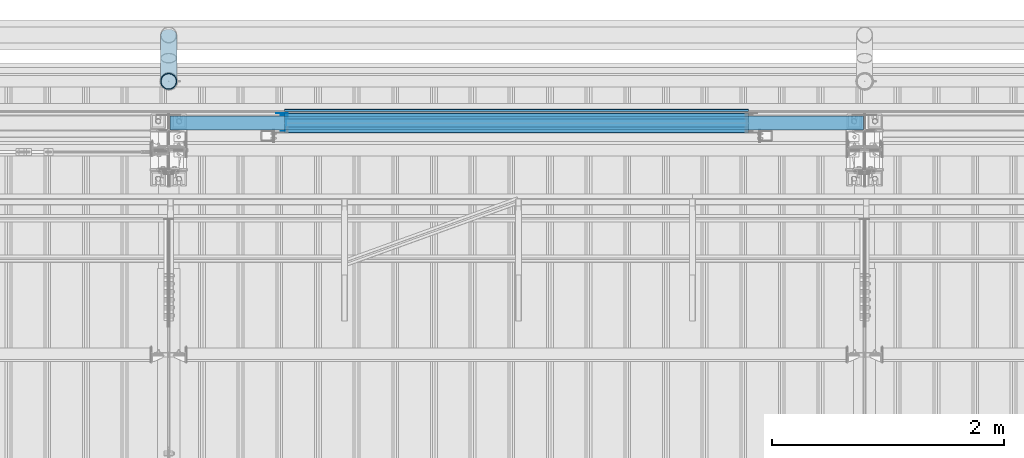
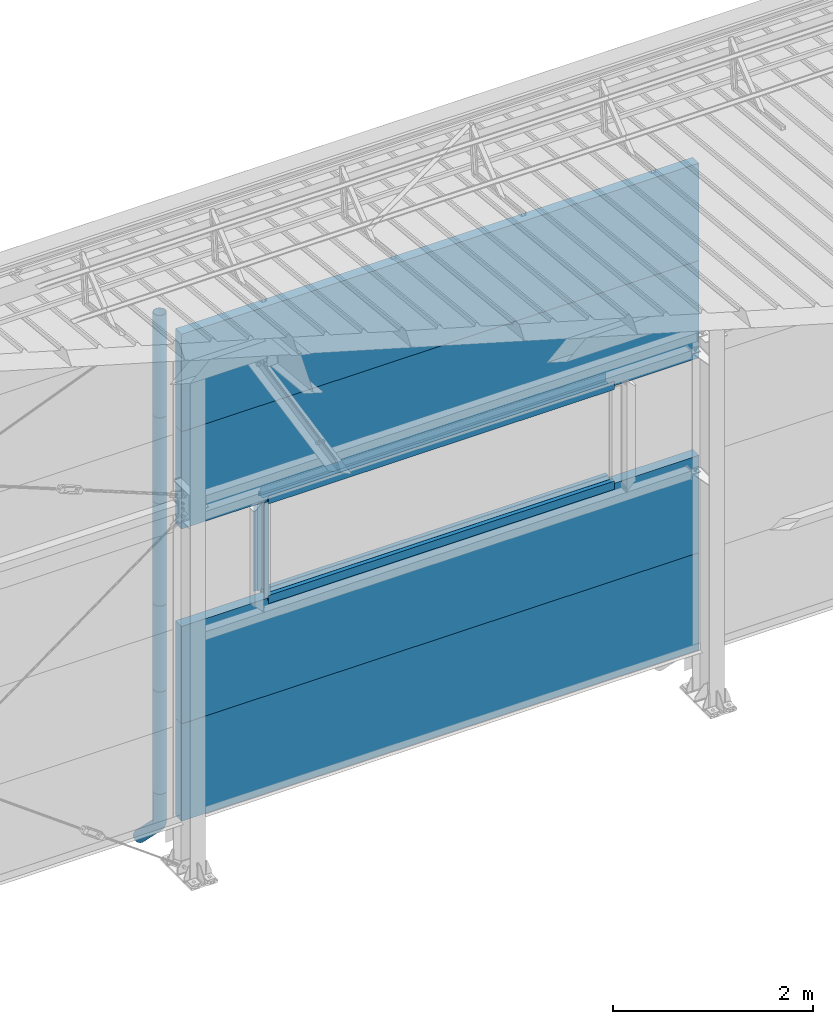
# One storey, part 62 of 709: 19 beams, 19 elements without a shape of their own.
"""IFC4 building model written with IfcOpenShell, lengths in millimetres."""

from ifc_helpers import new_model, entity, si_unit, direction, frame, origin_with_axes, place, context, subcontext, project, spatial, line, indexed_curve, outline, extrude, material, element, aggregate, save


model = new_model("IFC4")

# Units and contexts
model_context = context("Model", 3, precision=0.2, world=origin_with_axes(), true_north=direction((0.0, 1.0)))
body_context = subcontext(model_context, "Body", "Model", "MODEL_VIEW")
ifc_project = project(units=[si_unit("LENGTHUNIT", "METRE", prefix="MILLI"), si_unit("AREAUNIT", "SQUARE_METRE"), si_unit("VOLUMEUNIT", "CUBIC_METRE"), si_unit("MASSUNIT", "GRAM", prefix="KILO"), si_unit("TIMEUNIT", "SECOND"), si_unit("PLANEANGLEUNIT", "RADIAN"), si_unit("SOLIDANGLEUNIT", "STERADIAN"), si_unit("THERMODYNAMICTEMPERATUREUNIT", "DEGREE_CELSIUS"), si_unit("LUMINOUSINTENSITYUNIT", "LUMEN")], contexts=[model_context])

# Site, building, storey
site_placement = place(None, origin_with_axes())
site = spatial("IfcSite", under=ifc_project, at=site_placement, CompositionType="ELEMENT")
building_placement = place(site_placement, origin_with_axes())
building = spatial("IfcBuilding", under=site, at=building_placement, Name="Undefined", CompositionType="ELEMENT")
storey_placement = place(building_placement, origin_with_axes())
storey = spatial("IfcBuildingStorey", under=building, at=storey_placement, Name="Undefined", CompositionType="ELEMENT", Elevation=0.0)

# Assembly, beam
assembly_1_placement = place(storey_placement, frame((28010.0, 22060.0, 895.0), z_axis=(0.0, 0.0, -1.0), x_axis=(1.0, 0.0, 0.0)))
assembly_1 = element("IfcElementAssembly", 1, at=assembly_1_placement, inside=storey)
ifc_material_1 = material(Name="Insulation", Category="Insulation")
beam_1_placement = place(assembly_1_placement, origin_with_axes())
beam_1 = element("IfcBeam", 2, at=beam_1_placement, material=ifc_material_1, ObjectType="P-107", context=body_context, shape_type="SolidModel", body=[
    extrude(outline(indexed_curve([(-595.0, -60.0), (595.0, -60.0), (595.0, 60.0), (-595.0, 60.0)], segments=[line(1, 2, 3, 4, 1)])), frame((0.0, 0.0, 0.0), z_axis=(-1.0, 0.0, 0.0), x_axis=(0.0, 0.0, 1.0)), (0.0, 0.0, -1.0), 5980.0),
])
aggregate(assembly_1, [beam_1])

assembly_2_placement = place(storey_placement, frame((28010.0, 22060.0, 2085.0), z_axis=(0.0, 0.0, -1.0), x_axis=(1.0, 0.0, 0.0)))
assembly_2 = element("IfcElementAssembly", 3, at=assembly_2_placement, inside=storey)
beam_2_placement = place(assembly_2_placement, origin_with_axes())
beam_2 = element("IfcBeam", 4, at=beam_2_placement, material=ifc_material_1, ObjectType="P-107", context=body_context, shape_type="SolidModel", body=[
    extrude(outline(indexed_curve([(-595.0, -60.0), (595.0, -60.0), (595.0, 60.0), (-595.0, 60.0)], segments=[line(1, 2, 3, 4, 1)])), frame((0.0, 0.0, 0.0), z_axis=(-1.0, 0.0, 0.0), x_axis=(0.0, 0.0, 1.0)), (0.0, 0.0, -1.0), 5980.0),
])
aggregate(assembly_2, [beam_2])

assembly_3_placement = place(storey_placement, frame((28010.0, 22060.0, 4465.0), z_axis=(0.0, 0.0, -1.0), x_axis=(1.0, 0.0, 0.0)))
assembly_3 = element("IfcElementAssembly", 5, at=assembly_3_placement, inside=storey)
beam_3_placement = place(assembly_3_placement, origin_with_axes())
beam_3 = element("IfcBeam", 6, at=beam_3_placement, material=ifc_material_1, ObjectType="P-107", context=body_context, shape_type="SolidModel", body=[
    extrude(outline(indexed_curve([(-595.0, -60.0), (595.0, -60.0), (595.0, 60.0), (-595.0, 60.0)], segments=[line(1, 2, 3, 4, 1)])), frame((0.0, 0.0, 0.0), z_axis=(-1.0, 0.0, 0.0), x_axis=(0.0, 0.0, 1.0)), (0.0, 0.0, -1.0), 5980.0),
])
aggregate(assembly_3, [beam_3])

assembly_4_placement = place(storey_placement, frame((28010.0, 22060.0, 5655.0), z_axis=(0.0, 0.0, -1.0), x_axis=(1.0, 0.0, 0.0)))
assembly_4 = element("IfcElementAssembly", 7, at=assembly_4_placement, inside=storey)
beam_4_placement = place(assembly_4_placement, origin_with_axes())
beam_4 = element("IfcBeam", 8, at=beam_4_placement, material=ifc_material_1, ObjectType="P-107", context=body_context, shape_type="SolidModel", body=[
    extrude(outline(indexed_curve([(-595.0, -60.0), (595.0, -60.0), (595.0, 60.0), (-595.0, 60.0)], segments=[line(1, 2, 3, 4, 1)])), frame((0.0, 0.0, 0.0), z_axis=(-1.0, 0.0, 0.0), x_axis=(0.0, 0.0, 1.0)), (0.0, 0.0, -1.0), 5980.0),
])
aggregate(assembly_4, [beam_4])

assembly_5_placement = place(storey_placement, frame((33000.0, 22001.0, 2725.0), z_axis=(0.0, -1.0, 0.0), x_axis=(-1.0, 0.0, 0.0)))
assembly_5 = element("IfcElementAssembly", 9, at=assembly_5_placement, inside=storey)
ifc_material_2 = material(Name="Steel_Undefined", Category="STEEL")
beam_5_placement = place(assembly_5_placement, origin_with_axes())
beam_5 = element("IfcBeam", 10, at=beam_5_placement, material=ifc_material_2, context=body_context, shape_type="SolidModel", body=[
    extrude(outline(indexed_curve([(-25.0, -1.0), (25.0, -1.0), (25.0, 99.0), (23.0, 99.0), (23.0, 1.0), (-25.0, 1.0)], segments=[line(1, 2, 3, 4, 5, 6, 1)])), frame((0.0, 0.0, 0.0), z_axis=(-1.0, 0.0, 0.0), x_axis=(0.0, 0.0, 1.0)), (0.0, 0.0, -1.0), 4000.0),
])
aggregate(assembly_5, [beam_5])

assembly_6_placement = place(storey_placement, frame((33000.0, 22060.0, 2680.0), z_axis=(0.0, 1.0, 0.0), x_axis=(-1.0, 0.0, 0.0)))
assembly_6 = element("IfcElementAssembly", 11, at=assembly_6_placement, inside=storey)
beam_6_placement = place(assembly_6_placement, origin_with_axes())
beam_6 = element("IfcBeam", 12, at=beam_6_placement, material=ifc_material_2, context=body_context, shape_type="SolidModel", body=[
    extrude(outline(indexed_curve([(-70.0, -25.0), (-68.0, -25.0), (-68.0, 23.0), (68.0, 23.0), (68.0, -25.0), (70.0, -25.0), (70.0, 25.0), (-70.0, 25.0)], segments=[line(1, 2, 3, 4, 5, 6, 7, 8, 1)])), frame((0.0, 0.0, 0.0), z_axis=(-1.0, 0.0, 0.0), x_axis=(0.0, 0.0, 1.0)), (0.0, 0.0, -1.0), 4000.0),
])
aggregate(assembly_6, [beam_6])

assembly_7_placement = place(storey_placement, frame((29000.0, 22121.0, 2725.0), z_axis=(0.0, 1.0, 0.0), x_axis=(1.0, 0.0, 0.0)))
assembly_7 = element("IfcElementAssembly", 13, at=assembly_7_placement, inside=storey)
beam_7_placement = place(assembly_7_placement, origin_with_axes())
beam_7 = element("IfcBeam", 14, at=beam_7_placement, material=ifc_material_2, context=body_context, shape_type="SolidModel", body=[
    extrude(outline(indexed_curve([(-25.0, -1.0), (25.0, -1.0), (25.0, 99.0), (23.0, 99.0), (23.0, 1.0), (-25.0, 1.0)], segments=[line(1, 2, 3, 4, 5, 6, 1)])), frame((0.0, 0.0, 0.0), z_axis=(-1.0, 0.0, 0.0), x_axis=(0.0, 0.0, 1.0)), (0.0, 0.0, -1.0), 4000.0),
])
aggregate(assembly_7, [beam_7])

assembly_8_placement = place(storey_placement, frame((29000.0, 22001.0, 3845.0), z_axis=(0.0, -1.0, 0.0), x_axis=(1.0, 0.0, 0.0)))
assembly_8 = element("IfcElementAssembly", 15, at=assembly_8_placement, inside=storey)
beam_8_placement = place(assembly_8_placement, origin_with_axes())
beam_8 = element("IfcBeam", 16, at=beam_8_placement, material=ifc_material_2, context=body_context, shape_type="SolidModel", body=[
    extrude(outline(indexed_curve([(-25.0, -1.0), (25.0, -1.0), (25.0, 99.0), (23.0, 99.0), (23.0, 1.0), (-25.0, 1.0)], segments=[line(1, 2, 3, 4, 5, 6, 1)])), frame((0.0, 0.0, 0.0), z_axis=(-1.0, 0.0, 0.0), x_axis=(0.0, 0.0, 1.0)), (0.0, 0.0, -1.0), 4000.0),
])
aggregate(assembly_8, [beam_8])

assembly_9_placement = place(storey_placement, frame((33000.0, 22060.0, 3890.0), z_axis=(0.0, -1.0, 0.0), x_axis=(-1.0, 0.0, 0.0)))
assembly_9 = element("IfcElementAssembly", 17, at=assembly_9_placement, inside=storey)
beam_9_placement = place(assembly_9_placement, origin_with_axes())
beam_9 = element("IfcBeam", 18, at=beam_9_placement, material=ifc_material_2, context=body_context, shape_type="SolidModel", body=[
    extrude(outline(indexed_curve([(-70.0, -25.0), (-68.0, -25.0), (-68.0, 23.0), (68.0, 23.0), (68.0, -25.0), (70.0, -25.0), (70.0, 25.0), (-70.0, 25.0)], segments=[line(1, 2, 3, 4, 5, 6, 7, 8, 1)])), frame((0.0, 0.0, 0.0), z_axis=(-1.0, 0.0, 0.0), x_axis=(0.0, 0.0, 1.0)), (0.0, 0.0, -1.0), 4000.0),
])
aggregate(assembly_9, [beam_9])

assembly_10_placement = place(storey_placement, frame((33000.0, 22121.0, 3845.0), z_axis=(0.0, 1.0, 0.0), x_axis=(-1.0, 0.0, 0.0)))
assembly_10 = element("IfcElementAssembly", 19, at=assembly_10_placement, inside=storey)
beam_10_placement = place(assembly_10_placement, origin_with_axes())
beam_10 = element("IfcBeam", 20, at=beam_10_placement, material=ifc_material_2, context=body_context, shape_type="SolidModel", body=[
    extrude(outline(indexed_curve([(-25.0, -1.0), (25.0, -1.0), (25.0, 99.0), (23.0, 99.0), (23.0, 1.0), (-25.0, 1.0)], segments=[line(1, 2, 3, 4, 5, 6, 1)])), frame((0.0, 0.0, 0.0), z_axis=(-1.0, 0.0, 0.0), x_axis=(0.0, 0.0, 1.0)), (0.0, 0.0, -1.0), 4000.0),
])
aggregate(assembly_10, [beam_10])

assembly_11_placement = place(storey_placement, frame((33000.0, 22171.0, 3830.0), z_axis=(0.0, 1.0, 0.0), x_axis=(-1.0, 0.0, 0.0)))
assembly_11 = element("IfcElementAssembly", 21, at=assembly_11_placement, inside=storey)
beam_11_placement = place(assembly_11_placement, origin_with_axes())
beam_11 = element("IfcBeam", 22, at=beam_11_placement, material=ifc_material_2, context=body_context, shape_type="SolidModel", body=[
    extrude(outline(indexed_curve([(-10.0, -1.0), (10.0, -1.0), (10.0, 49.0), (8.0, 49.0), (8.0, 1.0), (-10.0, 1.0)], segments=[line(1, 2, 3, 4, 5, 6, 1)])), frame((0.0, 0.0, 0.0), z_axis=(-1.0, 0.0, 0.0), x_axis=(0.0, 0.0, 1.0)), (0.0, 0.0, -1.0), 4000.0),
])
aggregate(assembly_11, [beam_11])

assembly_12_placement = place(storey_placement, frame((28990.0, 22060.0, 3870.0), z_axis=(0.0, -1.0, 0.0), x_axis=(0.0, 0.0, -1.0)))
assembly_12 = element("IfcElementAssembly", 23, at=assembly_12_placement, inside=storey)
beam_12_placement = place(assembly_12_placement, origin_with_axes())
beam_12 = element("IfcBeam", 24, at=beam_12_placement, material=ifc_material_2, context=body_context, shape_type="SolidModel", body=[
    extrude(outline(indexed_curve([(-70.0, -25.0), (-68.0, -25.0), (-68.0, 23.0), (68.0, 23.0), (68.0, -25.0), (70.0, -25.0), (70.0, 25.0), (-70.0, 25.0)], segments=[line(1, 2, 3, 4, 5, 6, 7, 8, 1)])), frame((0.0, 0.0, 0.0), z_axis=(-1.0, 0.0, 0.0), x_axis=(0.0, 0.0, 1.0)), (0.0, 0.0, -1.0), 1170.0),
])
aggregate(assembly_12, [beam_12])

assembly_13_placement = place(storey_placement, frame((29025.0, 22121.0, 3870.0), z_axis=(0.0, 1.0, 0.0), x_axis=(0.0, 0.0, -1.0)))
assembly_13 = element("IfcElementAssembly", 25, at=assembly_13_placement, inside=storey)
beam_13_placement = place(assembly_13_placement, origin_with_axes())
beam_13 = element("IfcBeam", 26, at=beam_13_placement, material=ifc_material_2, context=body_context, shape_type="SolidModel", body=[
    extrude(outline(indexed_curve([(-25.0, -1.0), (25.0, -1.0), (25.0, 99.0), (23.0, 99.0), (23.0, 1.0), (-25.0, 1.0)], segments=[line(1, 2, 3, 4, 5, 6, 1)])), frame((0.0, 0.0, 0.0), z_axis=(-1.0, 0.0, 0.0), x_axis=(0.0, 0.0, 1.0)), (0.0, 0.0, -1.0), 1170.0),
])
aggregate(assembly_13, [beam_13])

assembly_14_placement = place(storey_placement, frame((28000.0, 22420.0, 6276.92297), z_axis=(0.0, -1.0, 0.0), x_axis=(0.0, 0.0, -1.0)))
assembly_14 = element("IfcElementAssembly", 27, at=assembly_14_placement, inside=storey)
beam_14_placement = place(assembly_14_placement, origin_with_axes())
beam_14 = element("IfcBeam", 28, at=beam_14_placement, material=ifc_material_2, ObjectType="614", context=body_context, shape_type="SolidModel", body=[
    extrude(outline(indexed_curve([(70.0, 0.0), (69.61653, 7.31699), (68.47033, 14.55382), (66.57396, 21.63119), (63.94818, 28.47157), (60.62178, 35.0), (56.63119, 41.14497), (52.02014, 46.83914), (46.83914, 52.02014), (41.14497, 56.63119), (35.0, 60.62178), (28.47157, 63.94818), (21.63119, 66.57396), (14.55382, 68.47033), (7.31699, 69.61653), (0.0, 70.0), (-7.31699, 69.61653), (-14.55382, 68.47033), (-21.63119, 66.57396), (-28.47157, 63.94818), (-35.0, 60.62178), (-41.14497, 56.63119), (-46.83914, 52.02014), (-52.02014, 46.83914), (-56.63119, 41.14497), (-60.62178, 35.0), (-63.94818, 28.47157), (-66.57396, 21.63119), (-68.47033, 14.55382), (-69.61653, 7.31699), (-70.0, 0.0), (-69.61653, -7.31699), (-68.47033, -14.55382), (-66.57396, -21.63119), (-63.94818, -28.47157), (-60.62178, -35.0), (-56.63119, -41.14497), (-52.02014, -46.83914), (-46.83914, -52.02014), (-41.14497, -56.63119), (-35.0, -60.62178), (-28.47157, -63.94818), (-21.63119, -66.57396), (-14.55382, -68.47033), (-7.31699, -69.61653), (0.0, -70.0), (7.31699, -69.61653), (14.55382, -68.47033), (21.63119, -66.57396), (28.47157, -63.94818), (35.0, -60.62178), (41.14497, -56.63119), (46.83914, -52.02014), (52.02014, -46.83914), (56.63119, -41.14497), (60.62178, -35.0), (63.94818, -28.47157), (66.57396, -21.63119), (68.47033, -14.55382), (69.61653, -7.31699)], segments=[line(1, 2, 3, 4, 5, 6, 7, 8, 9, 10, 11, 12, 13, 14, 15, 16, 17, 18, 19, 20, 21, 22, 23, 24, 25, 26, 27, 28, 29, 30, 31, 32, 33, 34, 35, 36, 37, 38, 39, 40, 41, 42, 43, 44, 45, 46, 47, 48, 49, 50, 51, 52, 53, 54, 55, 56, 57, 58, 59, 60, 1)]), holes=[indexed_curve([(65.0, 0.0), (64.64392, -6.79435), (63.57959, -13.51426), (61.81867, -20.0861), (59.38045, -26.43788), (56.29165, -32.5), (52.5861, -38.20604), (48.30441, -43.49349), (43.49349, -48.30441), (38.20604, -52.5861), (32.5, -56.29165), (26.43788, -59.38045), (20.0861, -61.81867), (13.51426, -63.57959), (6.79435, -64.64392), (0.0, -65.0), (-6.79435, -64.64392), (-13.51426, -63.57959), (-20.0861, -61.81867), (-26.43788, -59.38045), (-32.5, -56.29165), (-38.20604, -52.5861), (-43.49349, -48.30441), (-48.30441, -43.49349), (-52.5861, -38.20604), (-56.29165, -32.5), (-59.38045, -26.43788), (-61.81867, -20.0861), (-63.57959, -13.51426), (-64.64392, -6.79435), (-65.0, 0.0), (-64.64392, 6.79435), (-63.57959, 13.51426), (-61.81867, 20.0861), (-59.38045, 26.43788), (-56.29165, 32.5), (-52.5861, 38.20604), (-48.30441, 43.49349), (-43.49349, 48.30441), (-38.20604, 52.5861), (-32.5, 56.29165), (-26.43788, 59.38045), (-20.0861, 61.81867), (-13.51426, 63.57959), (-6.79435, 64.64392), (0.0, 65.0), (6.79435, 64.64392), (13.51426, 63.57959), (20.0861, 61.81867), (26.43788, 59.38045), (32.5, 56.29165), (38.20604, 52.5861), (43.49349, 48.30441), (48.30441, 43.49349), (52.5861, 38.20604), (56.29165, 32.5), (59.38045, 26.43788), (61.81867, 20.0861), (63.57959, 13.51426), (64.64392, 6.79435)], segments=[line(1, 2, 3, 4, 5, 6, 7, 8, 9, 10, 11, 12, 13, 14, 15, 16, 17, 18, 19, 20, 21, 22, 23, 24, 25, 26, 27, 28, 29, 30, 31, 32, 33, 34, 35, 36, 37, 38, 39, 40, 41, 42, 43, 44, 45, 46, 47, 48, 49, 50, 51, 52, 53, 54, 55, 56, 57, 58, 59, 60, 1)])]), frame((0.0, 0.0, 0.0), z_axis=(-1.0, 0.0, 0.0), x_axis=(0.0, 0.0, 1.0)), (0.0, 0.0, -1.0), 1250.0),
])
aggregate(assembly_14, [beam_14])

assembly_15_placement = place(storey_placement, frame((28000.0, 22420.0, 5126.92297), z_axis=(0.0, -1.0, 0.0), x_axis=(0.0, 0.0, -1.0)))
assembly_15 = element("IfcElementAssembly", 29, at=assembly_15_placement, inside=storey)
beam_15_placement = place(assembly_15_placement, origin_with_axes())
beam_15 = element("IfcBeam", 30, at=beam_15_placement, material=ifc_material_2, ObjectType="614", context=body_context, shape_type="SolidModel", body=[
    extrude(outline(indexed_curve([(70.0, 0.0), (69.61653, 7.31699), (68.47033, 14.55382), (66.57396, 21.63119), (63.94818, 28.47157), (60.62178, 35.0), (56.63119, 41.14497), (52.02014, 46.83914), (46.83914, 52.02014), (41.14497, 56.63119), (35.0, 60.62178), (28.47157, 63.94818), (21.63119, 66.57396), (14.55382, 68.47033), (7.31699, 69.61653), (0.0, 70.0), (-7.31699, 69.61653), (-14.55382, 68.47033), (-21.63119, 66.57396), (-28.47157, 63.94818), (-35.0, 60.62178), (-41.14497, 56.63119), (-46.83914, 52.02014), (-52.02014, 46.83914), (-56.63119, 41.14497), (-60.62178, 35.0), (-63.94818, 28.47157), (-66.57396, 21.63119), (-68.47033, 14.55382), (-69.61653, 7.31699), (-70.0, 0.0), (-69.61653, -7.31699), (-68.47033, -14.55382), (-66.57396, -21.63119), (-63.94818, -28.47157), (-60.62178, -35.0), (-56.63119, -41.14497), (-52.02014, -46.83914), (-46.83914, -52.02014), (-41.14497, -56.63119), (-35.0, -60.62178), (-28.47157, -63.94818), (-21.63119, -66.57396), (-14.55382, -68.47033), (-7.31699, -69.61653), (0.0, -70.0), (7.31699, -69.61653), (14.55382, -68.47033), (21.63119, -66.57396), (28.47157, -63.94818), (35.0, -60.62178), (41.14497, -56.63119), (46.83914, -52.02014), (52.02014, -46.83914), (56.63119, -41.14497), (60.62178, -35.0), (63.94818, -28.47157), (66.57396, -21.63119), (68.47033, -14.55382), (69.61653, -7.31699)], segments=[line(1, 2, 3, 4, 5, 6, 7, 8, 9, 10, 11, 12, 13, 14, 15, 16, 17, 18, 19, 20, 21, 22, 23, 24, 25, 26, 27, 28, 29, 30, 31, 32, 33, 34, 35, 36, 37, 38, 39, 40, 41, 42, 43, 44, 45, 46, 47, 48, 49, 50, 51, 52, 53, 54, 55, 56, 57, 58, 59, 60, 1)]), holes=[indexed_curve([(65.0, 0.0), (64.64392, -6.79435), (63.57959, -13.51426), (61.81867, -20.0861), (59.38045, -26.43788), (56.29165, -32.5), (52.5861, -38.20604), (48.30441, -43.49349), (43.49349, -48.30441), (38.20604, -52.5861), (32.5, -56.29165), (26.43788, -59.38045), (20.0861, -61.81867), (13.51426, -63.57959), (6.79435, -64.64392), (0.0, -65.0), (-6.79435, -64.64392), (-13.51426, -63.57959), (-20.0861, -61.81867), (-26.43788, -59.38045), (-32.5, -56.29165), (-38.20604, -52.5861), (-43.49349, -48.30441), (-48.30441, -43.49349), (-52.5861, -38.20604), (-56.29165, -32.5), (-59.38045, -26.43788), (-61.81867, -20.0861), (-63.57959, -13.51426), (-64.64392, -6.79435), (-65.0, 0.0), (-64.64392, 6.79435), (-63.57959, 13.51426), (-61.81867, 20.0861), (-59.38045, 26.43788), (-56.29165, 32.5), (-52.5861, 38.20604), (-48.30441, 43.49349), (-43.49349, 48.30441), (-38.20604, 52.5861), (-32.5, 56.29165), (-26.43788, 59.38045), (-20.0861, 61.81867), (-13.51426, 63.57959), (-6.79435, 64.64392), (0.0, 65.0), (6.79435, 64.64392), (13.51426, 63.57959), (20.0861, 61.81867), (26.43788, 59.38045), (32.5, 56.29165), (38.20604, 52.5861), (43.49349, 48.30441), (48.30441, 43.49349), (52.5861, 38.20604), (56.29165, 32.5), (59.38045, 26.43788), (61.81867, 20.0861), (63.57959, 13.51426), (64.64392, 6.79435)], segments=[line(1, 2, 3, 4, 5, 6, 7, 8, 9, 10, 11, 12, 13, 14, 15, 16, 17, 18, 19, 20, 21, 22, 23, 24, 25, 26, 27, 28, 29, 30, 31, 32, 33, 34, 35, 36, 37, 38, 39, 40, 41, 42, 43, 44, 45, 46, 47, 48, 49, 50, 51, 52, 53, 54, 55, 56, 57, 58, 59, 60, 1)])]), frame((0.0, 0.0, 0.0), z_axis=(-1.0, 0.0, 0.0), x_axis=(0.0, 0.0, 1.0)), (0.0, 0.0, -1.0), 1250.0),
])
aggregate(assembly_15, [beam_15])

assembly_16_placement = place(storey_placement, frame((28000.0, 22420.0, 3976.92297), z_axis=(0.0, -1.0, 0.0), x_axis=(0.0, 0.0, -1.0)))
assembly_16 = element("IfcElementAssembly", 31, at=assembly_16_placement, inside=storey)
beam_16_placement = place(assembly_16_placement, origin_with_axes())
beam_16 = element("IfcBeam", 32, at=beam_16_placement, material=ifc_material_2, ObjectType="614", context=body_context, shape_type="SolidModel", body=[
    extrude(outline(indexed_curve([(70.0, 0.0), (69.61653, 7.31699), (68.47033, 14.55382), (66.57396, 21.63119), (63.94818, 28.47157), (60.62178, 35.0), (56.63119, 41.14497), (52.02014, 46.83914), (46.83914, 52.02014), (41.14497, 56.63119), (35.0, 60.62178), (28.47157, 63.94818), (21.63119, 66.57396), (14.55382, 68.47033), (7.31699, 69.61653), (0.0, 70.0), (-7.31699, 69.61653), (-14.55382, 68.47033), (-21.63119, 66.57396), (-28.47157, 63.94818), (-35.0, 60.62178), (-41.14497, 56.63119), (-46.83914, 52.02014), (-52.02014, 46.83914), (-56.63119, 41.14497), (-60.62178, 35.0), (-63.94818, 28.47157), (-66.57396, 21.63119), (-68.47033, 14.55382), (-69.61653, 7.31699), (-70.0, 0.0), (-69.61653, -7.31699), (-68.47033, -14.55382), (-66.57396, -21.63119), (-63.94818, -28.47157), (-60.62178, -35.0), (-56.63119, -41.14497), (-52.02014, -46.83914), (-46.83914, -52.02014), (-41.14497, -56.63119), (-35.0, -60.62178), (-28.47157, -63.94818), (-21.63119, -66.57396), (-14.55382, -68.47033), (-7.31699, -69.61653), (0.0, -70.0), (7.31699, -69.61653), (14.55382, -68.47033), (21.63119, -66.57396), (28.47157, -63.94818), (35.0, -60.62178), (41.14497, -56.63119), (46.83914, -52.02014), (52.02014, -46.83914), (56.63119, -41.14497), (60.62178, -35.0), (63.94818, -28.47157), (66.57396, -21.63119), (68.47033, -14.55382), (69.61653, -7.31699)], segments=[line(1, 2, 3, 4, 5, 6, 7, 8, 9, 10, 11, 12, 13, 14, 15, 16, 17, 18, 19, 20, 21, 22, 23, 24, 25, 26, 27, 28, 29, 30, 31, 32, 33, 34, 35, 36, 37, 38, 39, 40, 41, 42, 43, 44, 45, 46, 47, 48, 49, 50, 51, 52, 53, 54, 55, 56, 57, 58, 59, 60, 1)]), holes=[indexed_curve([(65.0, 0.0), (64.64392, -6.79435), (63.57959, -13.51426), (61.81867, -20.0861), (59.38045, -26.43788), (56.29165, -32.5), (52.5861, -38.20604), (48.30441, -43.49349), (43.49349, -48.30441), (38.20604, -52.5861), (32.5, -56.29165), (26.43788, -59.38045), (20.0861, -61.81867), (13.51426, -63.57959), (6.79435, -64.64392), (0.0, -65.0), (-6.79435, -64.64392), (-13.51426, -63.57959), (-20.0861, -61.81867), (-26.43788, -59.38045), (-32.5, -56.29165), (-38.20604, -52.5861), (-43.49349, -48.30441), (-48.30441, -43.49349), (-52.5861, -38.20604), (-56.29165, -32.5), (-59.38045, -26.43788), (-61.81867, -20.0861), (-63.57959, -13.51426), (-64.64392, -6.79435), (-65.0, 0.0), (-64.64392, 6.79435), (-63.57959, 13.51426), (-61.81867, 20.0861), (-59.38045, 26.43788), (-56.29165, 32.5), (-52.5861, 38.20604), (-48.30441, 43.49349), (-43.49349, 48.30441), (-38.20604, 52.5861), (-32.5, 56.29165), (-26.43788, 59.38045), (-20.0861, 61.81867), (-13.51426, 63.57959), (-6.79435, 64.64392), (0.0, 65.0), (6.79435, 64.64392), (13.51426, 63.57959), (20.0861, 61.81867), (26.43788, 59.38045), (32.5, 56.29165), (38.20604, 52.5861), (43.49349, 48.30441), (48.30441, 43.49349), (52.5861, 38.20604), (56.29165, 32.5), (59.38045, 26.43788), (61.81867, 20.0861), (63.57959, 13.51426), (64.64392, 6.79435)], segments=[line(1, 2, 3, 4, 5, 6, 7, 8, 9, 10, 11, 12, 13, 14, 15, 16, 17, 18, 19, 20, 21, 22, 23, 24, 25, 26, 27, 28, 29, 30, 31, 32, 33, 34, 35, 36, 37, 38, 39, 40, 41, 42, 43, 44, 45, 46, 47, 48, 49, 50, 51, 52, 53, 54, 55, 56, 57, 58, 59, 60, 1)])]), frame((0.0, 0.0, 0.0), z_axis=(-1.0, 0.0, 0.0), x_axis=(0.0, 0.0, 1.0)), (0.0, 0.0, -1.0), 1250.0),
])
aggregate(assembly_16, [beam_16])

assembly_17_placement = place(storey_placement, frame((28000.0, 22420.0, 2826.92297), z_axis=(0.0, -1.0, 0.0), x_axis=(0.0, 0.0, -1.0)))
assembly_17 = element("IfcElementAssembly", 33, at=assembly_17_placement, inside=storey)
beam_17_placement = place(assembly_17_placement, origin_with_axes())
beam_17 = element("IfcBeam", 34, at=beam_17_placement, material=ifc_material_2, ObjectType="614", context=body_context, shape_type="SolidModel", body=[
    extrude(outline(indexed_curve([(70.0, 0.0), (69.61653, 7.31699), (68.47033, 14.55382), (66.57396, 21.63119), (63.94818, 28.47157), (60.62178, 35.0), (56.63119, 41.14497), (52.02014, 46.83914), (46.83914, 52.02014), (41.14497, 56.63119), (35.0, 60.62178), (28.47157, 63.94818), (21.63119, 66.57396), (14.55382, 68.47033), (7.31699, 69.61653), (0.0, 70.0), (-7.31699, 69.61653), (-14.55382, 68.47033), (-21.63119, 66.57396), (-28.47157, 63.94818), (-35.0, 60.62178), (-41.14497, 56.63119), (-46.83914, 52.02014), (-52.02014, 46.83914), (-56.63119, 41.14497), (-60.62178, 35.0), (-63.94818, 28.47157), (-66.57396, 21.63119), (-68.47033, 14.55382), (-69.61653, 7.31699), (-70.0, 0.0), (-69.61653, -7.31699), (-68.47033, -14.55382), (-66.57396, -21.63119), (-63.94818, -28.47157), (-60.62178, -35.0), (-56.63119, -41.14497), (-52.02014, -46.83914), (-46.83914, -52.02014), (-41.14497, -56.63119), (-35.0, -60.62178), (-28.47157, -63.94818), (-21.63119, -66.57396), (-14.55382, -68.47033), (-7.31699, -69.61653), (0.0, -70.0), (7.31699, -69.61653), (14.55382, -68.47033), (21.63119, -66.57396), (28.47157, -63.94818), (35.0, -60.62178), (41.14497, -56.63119), (46.83914, -52.02014), (52.02014, -46.83914), (56.63119, -41.14497), (60.62178, -35.0), (63.94818, -28.47157), (66.57396, -21.63119), (68.47033, -14.55382), (69.61653, -7.31699)], segments=[line(1, 2, 3, 4, 5, 6, 7, 8, 9, 10, 11, 12, 13, 14, 15, 16, 17, 18, 19, 20, 21, 22, 23, 24, 25, 26, 27, 28, 29, 30, 31, 32, 33, 34, 35, 36, 37, 38, 39, 40, 41, 42, 43, 44, 45, 46, 47, 48, 49, 50, 51, 52, 53, 54, 55, 56, 57, 58, 59, 60, 1)]), holes=[indexed_curve([(65.0, 0.0), (64.64392, -6.79435), (63.57959, -13.51426), (61.81867, -20.0861), (59.38045, -26.43788), (56.29165, -32.5), (52.5861, -38.20604), (48.30441, -43.49349), (43.49349, -48.30441), (38.20604, -52.5861), (32.5, -56.29165), (26.43788, -59.38045), (20.0861, -61.81867), (13.51426, -63.57959), (6.79435, -64.64392), (0.0, -65.0), (-6.79435, -64.64392), (-13.51426, -63.57959), (-20.0861, -61.81867), (-26.43788, -59.38045), (-32.5, -56.29165), (-38.20604, -52.5861), (-43.49349, -48.30441), (-48.30441, -43.49349), (-52.5861, -38.20604), (-56.29165, -32.5), (-59.38045, -26.43788), (-61.81867, -20.0861), (-63.57959, -13.51426), (-64.64392, -6.79435), (-65.0, 0.0), (-64.64392, 6.79435), (-63.57959, 13.51426), (-61.81867, 20.0861), (-59.38045, 26.43788), (-56.29165, 32.5), (-52.5861, 38.20604), (-48.30441, 43.49349), (-43.49349, 48.30441), (-38.20604, 52.5861), (-32.5, 56.29165), (-26.43788, 59.38045), (-20.0861, 61.81867), (-13.51426, 63.57959), (-6.79435, 64.64392), (0.0, 65.0), (6.79435, 64.64392), (13.51426, 63.57959), (20.0861, 61.81867), (26.43788, 59.38045), (32.5, 56.29165), (38.20604, 52.5861), (43.49349, 48.30441), (48.30441, 43.49349), (52.5861, 38.20604), (56.29165, 32.5), (59.38045, 26.43788), (61.81867, 20.0861), (63.57959, 13.51426), (64.64392, 6.79435)], segments=[line(1, 2, 3, 4, 5, 6, 7, 8, 9, 10, 11, 12, 13, 14, 15, 16, 17, 18, 19, 20, 21, 22, 23, 24, 25, 26, 27, 28, 29, 30, 31, 32, 33, 34, 35, 36, 37, 38, 39, 40, 41, 42, 43, 44, 45, 46, 47, 48, 49, 50, 51, 52, 53, 54, 55, 56, 57, 58, 59, 60, 1)])]), frame((0.0, 0.0, 0.0), z_axis=(-1.0, 0.0, 0.0), x_axis=(0.0, 0.0, 1.0)), (0.0, 0.0, -1.0), 1250.0),
])
aggregate(assembly_17, [beam_17])

assembly_18_placement = place(storey_placement, frame((28000.0, 22420.0, 1676.92297), z_axis=(0.0, -1.0, 0.0), x_axis=(0.0, 0.0, -1.0)))
assembly_18 = element("IfcElementAssembly", 35, at=assembly_18_placement, inside=storey)
beam_18_placement = place(assembly_18_placement, origin_with_axes())
beam_18 = element("IfcBeam", 36, at=beam_18_placement, material=ifc_material_2, ObjectType="614", context=body_context, shape_type="SolidModel", body=[
    extrude(outline(indexed_curve([(70.0, 0.0), (69.61653, 7.31699), (68.47033, 14.55382), (66.57396, 21.63119), (63.94818, 28.47157), (60.62178, 35.0), (56.63119, 41.14497), (52.02014, 46.83914), (46.83914, 52.02014), (41.14497, 56.63119), (35.0, 60.62178), (28.47157, 63.94818), (21.63119, 66.57396), (14.55382, 68.47033), (7.31699, 69.61653), (0.0, 70.0), (-7.31699, 69.61653), (-14.55382, 68.47033), (-21.63119, 66.57396), (-28.47157, 63.94818), (-35.0, 60.62178), (-41.14497, 56.63119), (-46.83914, 52.02014), (-52.02014, 46.83914), (-56.63119, 41.14497), (-60.62178, 35.0), (-63.94818, 28.47157), (-66.57396, 21.63119), (-68.47033, 14.55382), (-69.61653, 7.31699), (-70.0, 0.0), (-69.61653, -7.31699), (-68.47033, -14.55382), (-66.57396, -21.63119), (-63.94818, -28.47157), (-60.62178, -35.0), (-56.63119, -41.14497), (-52.02014, -46.83914), (-46.83914, -52.02014), (-41.14497, -56.63119), (-35.0, -60.62178), (-28.47157, -63.94818), (-21.63119, -66.57396), (-14.55382, -68.47033), (-7.31699, -69.61653), (0.0, -70.0), (7.31699, -69.61653), (14.55382, -68.47033), (21.63119, -66.57396), (28.47157, -63.94818), (35.0, -60.62178), (41.14497, -56.63119), (46.83914, -52.02014), (52.02014, -46.83914), (56.63119, -41.14497), (60.62178, -35.0), (63.94818, -28.47157), (66.57396, -21.63119), (68.47033, -14.55382), (69.61653, -7.31699)], segments=[line(1, 2, 3, 4, 5, 6, 7, 8, 9, 10, 11, 12, 13, 14, 15, 16, 17, 18, 19, 20, 21, 22, 23, 24, 25, 26, 27, 28, 29, 30, 31, 32, 33, 34, 35, 36, 37, 38, 39, 40, 41, 42, 43, 44, 45, 46, 47, 48, 49, 50, 51, 52, 53, 54, 55, 56, 57, 58, 59, 60, 1)]), holes=[indexed_curve([(65.0, 0.0), (64.64392, -6.79435), (63.57959, -13.51426), (61.81867, -20.0861), (59.38045, -26.43788), (56.29165, -32.5), (52.5861, -38.20604), (48.30441, -43.49349), (43.49349, -48.30441), (38.20604, -52.5861), (32.5, -56.29165), (26.43788, -59.38045), (20.0861, -61.81867), (13.51426, -63.57959), (6.79435, -64.64392), (0.0, -65.0), (-6.79435, -64.64392), (-13.51426, -63.57959), (-20.0861, -61.81867), (-26.43788, -59.38045), (-32.5, -56.29165), (-38.20604, -52.5861), (-43.49349, -48.30441), (-48.30441, -43.49349), (-52.5861, -38.20604), (-56.29165, -32.5), (-59.38045, -26.43788), (-61.81867, -20.0861), (-63.57959, -13.51426), (-64.64392, -6.79435), (-65.0, 0.0), (-64.64392, 6.79435), (-63.57959, 13.51426), (-61.81867, 20.0861), (-59.38045, 26.43788), (-56.29165, 32.5), (-52.5861, 38.20604), (-48.30441, 43.49349), (-43.49349, 48.30441), (-38.20604, 52.5861), (-32.5, 56.29165), (-26.43788, 59.38045), (-20.0861, 61.81867), (-13.51426, 63.57959), (-6.79435, 64.64392), (0.0, 65.0), (6.79435, 64.64392), (13.51426, 63.57959), (20.0861, 61.81867), (26.43788, 59.38045), (32.5, 56.29165), (38.20604, 52.5861), (43.49349, 48.30441), (48.30441, 43.49349), (52.5861, 38.20604), (56.29165, 32.5), (59.38045, 26.43788), (61.81867, 20.0861), (63.57959, 13.51426), (64.64392, 6.79435)], segments=[line(1, 2, 3, 4, 5, 6, 7, 8, 9, 10, 11, 12, 13, 14, 15, 16, 17, 18, 19, 20, 21, 22, 23, 24, 25, 26, 27, 28, 29, 30, 31, 32, 33, 34, 35, 36, 37, 38, 39, 40, 41, 42, 43, 44, 45, 46, 47, 48, 49, 50, 51, 52, 53, 54, 55, 56, 57, 58, 59, 60, 1)])]), frame((0.0, 0.0, 0.0), z_axis=(-1.0, 0.0, 0.0), x_axis=(0.0, 0.0, 1.0)), (0.0, 0.0, -1.0), 1250.0),
])
aggregate(assembly_18, [beam_18])

assembly_19_placement = place(storey_placement, frame((28000.0, 22420.0, 526.92297), z_axis=(1.0, 0.0, 0.0), x_axis=(0.0, 0.0, -1.0)))
assembly_19 = element("IfcElementAssembly", 37, at=assembly_19_placement, inside=storey)
beam_19_placement = place(assembly_19_placement, origin_with_axes())
beam_19 = element("IfcBeam", 38, at=beam_19_placement, material=ifc_material_2, ObjectType="617", context=body_context, shape_type="SolidModel", body=[
    entity("IfcSweptDiskSolid", entity("IfcIndexedPolyCurve", entity("IfcCartesianPointList3D", [[0.0, 0.0, 0.0], [448.2233, 0.0, 0.0], [496.05873, 9.51506, 0.0], [536.61165, 36.61165, 0.0], [900.0, 400.0, 0.0]]), [entity("IfcLineIndex", [1, 2]), entity("IfcArcIndex", [2, 3, 4]), entity("IfcLineIndex", [4, 5])]), 70.0, 65.0),
])
aggregate(assembly_19, [beam_19])

save(model, "model.ifc")
